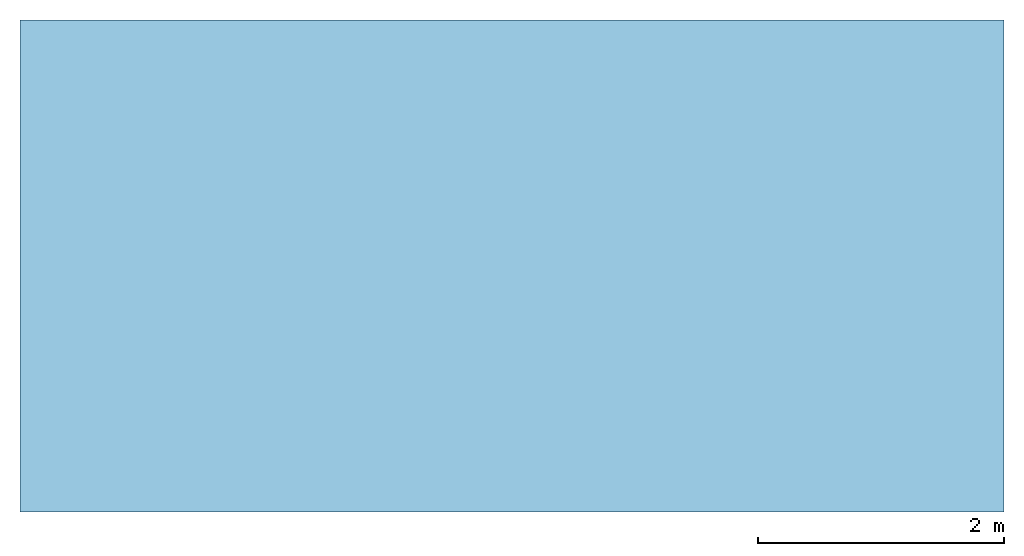
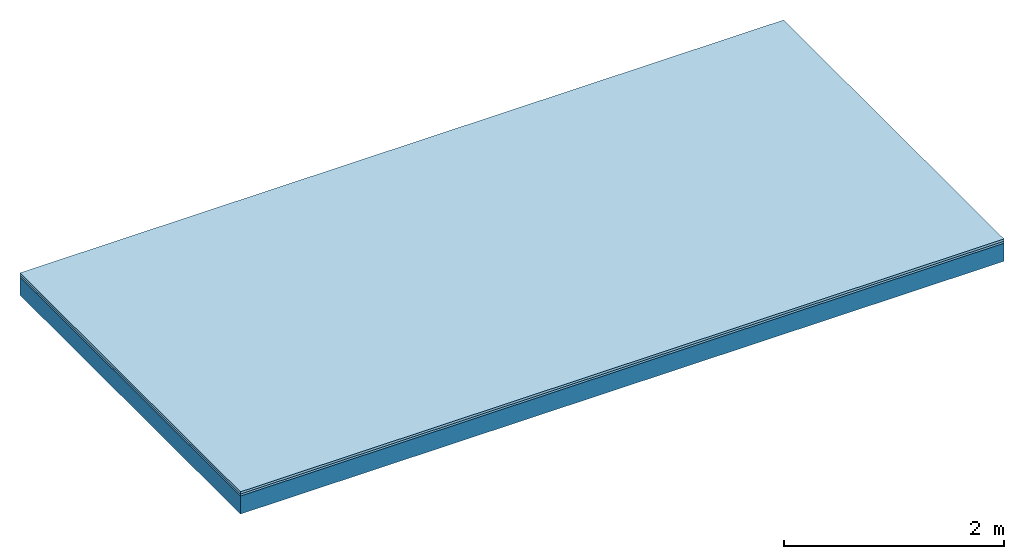
# One storey: 2 plates, 1 member, 1 element without a shape of its own.
"""IFC4 building model written with IfcOpenShell, lengths in metres."""

from ifc_helpers import new_model, si_unit, derived_unit, direction, frame, frame_2d, origin, origin_with_axes, place, context, project, spatial, rectangle, extrude, material, layer, layer_set, type_object, element, aggregate, save


model = new_model("IFC4")

# Units and contexts
plan_context = context("Plan", 3, precision=1e-05, world=origin(), true_north=direction((0.0, 1.0)))
model_context = context("Model", 3, precision=1e-05, world=origin(), true_north=direction((0.0, 1.0)))
ifc_project = project(units=[si_unit("LENGTHUNIT", "METRE"), derived_unit("SOUNDPRESSUREUNIT", [(si_unit("PRESSUREUNIT", "PASCAL", prefix="MICRO"), 0)]), si_unit("ENERGYUNIT", "JOULE", prefix="MEGA"), si_unit("MASSUNIT", "GRAM", prefix="KILO"), derived_unit("THERMALTRANSMITTANCEUNIT", [(si_unit("POWERUNIT", "WATT"), 1), (si_unit("AREAUNIT", "SQUARE_METRE"), -1), (si_unit("THERMODYNAMICTEMPERATUREUNIT", "KELVIN"), -1)]), derived_unit("AREADENSITYUNIT", [(si_unit("MASSUNIT", "GRAM", prefix="KILO"), 1), (si_unit("AREAUNIT", "SQUARE_METRE"), -1)]), derived_unit("USERDEFINED", [(si_unit("ENERGYUNIT", "JOULE", prefix="MEGA"), 1), (si_unit("AREAUNIT", "SQUARE_METRE"), -1)])], contexts=[plan_context, model_context])

# Site, building, storey
site = spatial("IfcSite", under=ifc_project)
building_placement = place(None, origin())
building = spatial("IfcBuilding", under=site, at=building_placement)
storey_placement = place(building_placement, origin())
storey = spatial("IfcBuildingStorey", under=building, at=storey_placement)

# Slab, member, plates
ifc_material_1 = material(Name="Floor heating system Therm38 longitudinal", Category="03.007")
ifc_layer_1 = layer(ifc_material_1, 0.025, Name="On-material")
ifc_material_2 = material(Category="10.009")
ifc_layer_2 = layer(ifc_material_2, 0.022, Name="Impact sound insulation")
ifc_layer_3 = layer(None, 0.2, Name="Supporting structure")
ifc_layer_set = layer_set([ifc_layer_1, ifc_layer_2, ifc_layer_3])
slab_type = type_object("IfcSlabType", Name="A0841", PredefinedType="NOTDEFINED", material=ifc_layer_set)
slab_placement = place(None, frame((0.0, 0.0, 0.0), z_axis=(0.0, 0.0, -1.0), x_axis=(1.0, 0.0, 0.0)))
slab = element("IfcSlab", 1, at=slab_placement, inside=storey, type_object=slab_type, material=ifc_layer_set, Name="Slab #1")
ifc_material_3 = material()
member_placement = place(slab_placement, origin())
member = element("IfcMember", 2, at=member_placement, material=ifc_material_3, Name="Supporting structure", context=plan_context, shape_type="SweptSolid", body=[
    extrude(rectangle(XDim=1.0, YDim=0.2, at=frame_2d((0.5, 0.1), x_axis=(1.0, 0.0))), frame((0.0, 4.0, 0.047), z_axis=(0.0, -1.0, 0.0), x_axis=(1.0, 0.0, 0.0)), (0.0, 0.0, 1.0), 4.0),
    extrude(rectangle(XDim=1.0, YDim=0.2, at=frame_2d((0.5, 0.1), x_axis=(1.0, 0.0))), frame((1.0, 4.0, 0.047), z_axis=(0.0, -1.0, 0.0), x_axis=(1.0, 0.0, 0.0)), (0.0, 0.0, 1.0), 4.0),
    extrude(rectangle(XDim=1.0, YDim=0.2, at=frame_2d((0.5, 0.1), x_axis=(1.0, 0.0))), frame((2.0, 4.0, 0.047), z_axis=(0.0, -1.0, 0.0), x_axis=(1.0, 0.0, 0.0)), (0.0, 0.0, 1.0), 4.0),
    extrude(rectangle(XDim=1.0, YDim=0.2, at=frame_2d((0.5, 0.1), x_axis=(1.0, 0.0))), frame((3.0, 4.0, 0.047), z_axis=(0.0, -1.0, 0.0), x_axis=(1.0, 0.0, 0.0)), (0.0, 0.0, 1.0), 4.0),
    extrude(rectangle(XDim=1.0, YDim=0.2, at=frame_2d((0.5, 0.1), x_axis=(1.0, 0.0))), frame((4.0, 4.0, 0.047), z_axis=(0.0, -1.0, 0.0), x_axis=(1.0, 0.0, 0.0)), (0.0, 0.0, 1.0), 4.0),
    extrude(rectangle(XDim=1.0, YDim=0.2, at=frame_2d((0.5, 0.1), x_axis=(1.0, 0.0))), frame((5.0, 4.0, 0.047), z_axis=(0.0, -1.0, 0.0), x_axis=(1.0, 0.0, 0.0)), (0.0, 0.0, 1.0), 4.0),
    extrude(rectangle(XDim=1.0, YDim=0.2, at=frame_2d((0.5, 0.1), x_axis=(1.0, 0.0))), frame((6.0, 4.0, 0.047), z_axis=(0.0, -1.0, 0.0), x_axis=(1.0, 0.0, 0.0)), (0.0, 0.0, 1.0), 4.0),
    extrude(rectangle(XDim=1.0, YDim=0.2, at=frame_2d((0.5, 0.1), x_axis=(1.0, 0.0))), frame((7.0, 4.0, 0.047), z_axis=(0.0, -1.0, 0.0), x_axis=(1.0, 0.0, 0.0)), (0.0, 0.0, 1.0), 4.0),
])
plate_1_placement = place(slab_placement, origin())
plate_1 = element("IfcPlate", 3, at=plate_1_placement, material=ifc_material_1, Name="On-material", context=plan_context, shape_type="SweptSolid", body=[
    extrude(rectangle(XDim=8.0, YDim=4.0, at=frame_2d((4.0, 2.0), x_axis=(1.0, 0.0))), origin_with_axes(), (0.0, 0.0, 1.0), 0.025),
])
plate_2_placement = place(slab_placement, origin())
plate_2 = element("IfcPlate", 4, at=plate_2_placement, material=ifc_material_2, Name="Impact sound insulation", context=plan_context, shape_type="SweptSolid", body=[
    extrude(rectangle(XDim=8.0, YDim=4.0, at=frame_2d((4.0, 2.0), x_axis=(1.0, 0.0))), frame((0.0, 0.0, 0.025), z_axis=(0.0, 0.0, 1.0), x_axis=(1.0, 0.0, 0.0)), (0.0, 0.0, 1.0), 0.022),
])
aggregate(slab, [plate_1, plate_2, member])

save(model, "model.ifc")
